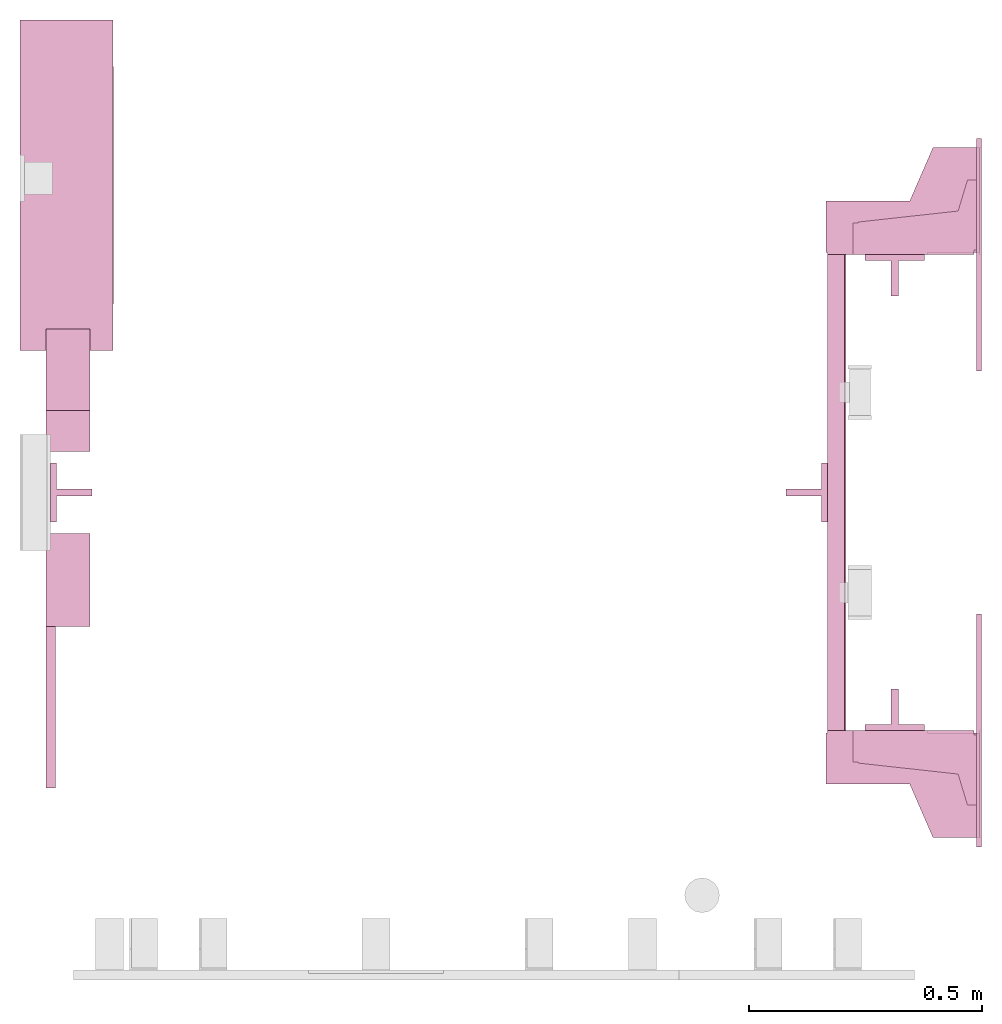
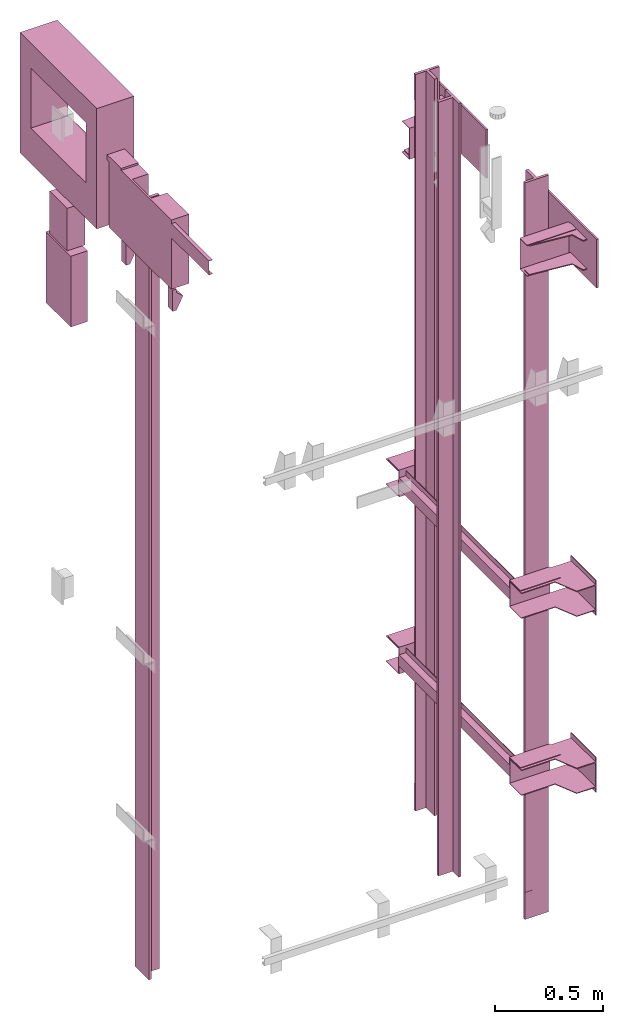
# One storey, part 3 of 4: 9 transport elements.
"""IFC4 building model written with IfcOpenShell, lengths in millimetres."""

from ifc_helpers import new_model, entity, si_unit, converted_unit, frame, origin_with_axes, place, context, subcontext, project, spatial, faceted_brep, element, save


model = new_model("IFC4")

# Units and contexts
context_of_model = context(None, 3, precision=0.01, world=origin_with_axes())
sub_context_1 = subcontext(context_of_model, None, None, "MODEL_VIEW")
sub_context_2 = subcontext(context_of_model, None, None, "MODEL_VIEW")
sub_context_3 = subcontext(context_of_model, None, None, "MODEL_VIEW")
sub_context_4 = subcontext(context_of_model, None, None, "MODEL_VIEW")
sub_context_5 = subcontext(context_of_model, None, None, "MODEL_VIEW")
sub_context_6 = subcontext(context_of_model, None, None, "MODEL_VIEW")
sub_context_7 = subcontext(context_of_model, None, None, "MODEL_VIEW")
sub_context_8 = subcontext(context_of_model, None, None, "MODEL_VIEW")
sub_context_9 = subcontext(context_of_model, None, None, "MODEL_VIEW")
ifc_project = project(units=[converted_unit("PLANEANGLEUNIT", "degree", entity("IfcPlaneAngleMeasure", 0.017453292519943), si_unit("PLANEANGLEUNIT", "RADIAN"), dimensions=[0, 0, 0, 0, 0, 0, 0]), si_unit("LENGTHUNIT", "METRE", prefix="MILLI"), si_unit("MASSUNIT", "GRAM", prefix="KILO"), converted_unit("TIMEUNIT", "year", entity("IfcTimeMeasure", 31557600.0), si_unit("TIMEUNIT", "SECOND"), dimensions=[0, 0, 1, 0, 0, 0, 0]), si_unit("THERMODYNAMICTEMPERATUREUNIT", "DEGREE_CELSIUS"), si_unit("AREAUNIT", "SQUARE_METRE"), si_unit("FORCEUNIT", "NEWTON"), si_unit("VOLUMEUNIT", "CUBIC_METRE"), si_unit("PRESSUREUNIT", "PASCAL"), si_unit("SOLIDANGLEUNIT", "STERADIAN")], contexts=[context_of_model])

# Site, building, storey
site = spatial("IfcSite", under=ifc_project)
building = spatial("IfcBuilding", under=site, Name="Document")
placement = place(None, origin_with_axes())
storey_placement = place(placement, frame((0.0, 0.0, 4420.0), z_axis=(0.0, 0.0, 1.0), x_axis=(1.0, 0.0, 0.0)))
storey = spatial("IfcBuildingStorey", under=building, at=storey_placement, Name="1", Elevation=4420.0)

# Transport elements
transport_element_1_placement = place(storey_placement, frame((2065.0, 1025.0, 64.0), z_axis=(0.0, 0.0, 1.0), x_axis=(0.0, 1.0, 0.0)))
element("IfcTransportElement", 1, at=transport_element_1_placement, inside=storey, PredefinedType="ELEVATOR", context=sub_context_1, shape_type="Brep", body=[
    faceted_brep([(-511.0, 291.0, -32.5), (-511.0, 294.0, -32.5), (-511.0, 294.0, -59.5), (-511.0, 291.0, -59.5), (511.0, 291.0, -32.5), (511.0, 291.0, -59.5), (511.0, 294.0, -59.5), (511.0, 294.0, -32.5)], [[[0, 1, 2, 3]], [[4, 5, 6, 7]], [[0, 3, 5, 4]], [[3, 2, 6, 5]], [[2, 1, 7, 6]], [[1, 0, 4, 7]]]),
    faceted_brep([(-511.0, 291.0, 59.5), (-511.0, 294.0, 59.5), (-511.0, 294.0, 32.5), (-511.0, 291.0, 32.5), (511.0, 291.0, 59.5), (511.0, 291.0, 32.5), (511.0, 294.0, 32.5), (511.0, 294.0, 59.5)], [[[0, 1, 2, 3]], [[4, 5, 6, 7]], [[0, 3, 5, 4]], [[3, 2, 6, 5]], [[2, 1, 7, 6]], [[1, 0, 4, 7]]]),
    faceted_brep([(-611.0, 331.0, -72.5), (-514.0, 331.0, -72.5), (-514.0, 331.0, 72.5), (-611.0, 331.0, 72.5), (-611.0, 331.0, 75.5), (-511.0, 331.0, 75.5), (-511.0, 331.0, -75.5), (-611.0, 331.0, -75.5), (-511.0, 116.0, -75.5), (-511.0, 116.0, 75.5), (-611.0, 116.0, 75.5), (-611.0, 116.0, 72.5), (-514.0, 116.0, 72.5), (-514.0, 116.0, -72.5), (-611.0, 116.0, -72.5), (-611.0, 116.0, -75.5)], [[[0, 1, 2, 3, 4, 5, 6, 7]], [[8, 9, 10, 11, 12, 13, 14, 15]], [[15, 14, 0, 7]], [[13, 12, 2, 1]], [[5, 9, 8, 6]], [[11, 10, 4, 3]], [[6, 8, 15, 7]], [[14, 13, 1, 0]], [[2, 12, 11, 3]], [[10, 9, 5, 4]]]),
    faceted_brep([(-511.0, 331.0, 32.5), (511.0, 331.0, 32.5), (511.0, 331.0, -32.5), (-511.0, 331.0, -32.5), (511.0, 328.0, -29.5), (511.0, 328.0, 29.5), (-511.0, 328.0, 29.5), (-511.0, 328.0, -29.5), (511.0, 291.0, -32.5), (511.0, 291.0, -29.5), (-511.0, 291.0, -29.5), (-511.0, 291.0, -32.5), (511.0, 291.0, 29.5), (511.0, 291.0, 32.5), (-511.0, 291.0, 32.5), (-511.0, 291.0, 29.5)], [[[0, 1, 2, 3]], [[4, 5, 6, 7]], [[8, 9, 10, 11]], [[12, 13, 14, 15]], [[11, 10, 7, 6, 15, 14, 0, 3]], [[2, 1, 13, 12, 5, 4, 9, 8]], [[2, 8, 11, 3]], [[10, 9, 4, 7]], [[14, 13, 1, 0]], [[5, 12, 15, 6]]]),
    faceted_brep([(516.0, 334.0, 72.5), (626.0, 334.0, 72.5), (626.0, 334.0, 68.5), (516.0, 334.0, 68.5), (741.0, 4.0, 68.5), (741.0, 4.0, 72.5), (516.0, 4.0, 72.5), (516.0, 4.0, 68.5), (626.0, 154.0, 72.5), (741.0, 104.0, 72.5), (741.0, 104.0, 68.5), (626.0, 154.0, 68.5)], [[[0, 1, 2, 3]], [[4, 5, 6, 7]], [[8, 9, 10, 11]], [[7, 6, 0, 3]], [[1, 8, 11, 2]], [[9, 5, 4, 10]], [[2, 11, 10, 4, 7, 3]], [[6, 5, 9, 8, 1, 0]]]),
    faceted_brep([(516.0, 334.0, -68.5), (626.0, 334.0, -68.5), (626.0, 334.0, -72.5), (516.0, 334.0, -72.5), (741.0, 4.0, -72.5), (741.0, 4.0, -68.5), (516.0, 4.0, -68.5), (516.0, 4.0, -72.5), (626.0, 154.0, -68.5), (741.0, 104.0, -68.5), (741.0, 104.0, -72.5), (626.0, 154.0, -72.5)], [[[0, 1, 2, 3]], [[4, 5, 6, 7]], [[8, 9, 10, 11]], [[7, 6, 0, 3]], [[1, 8, 11, 2]], [[9, 5, 4, 10]], [[2, 11, 10, 4, 7, 3]], [[6, 5, 9, 8, 1, 0]]]),
    faceted_brep([(-626.0, 334.0, -68.5), (-516.0, 334.0, -68.5), (-516.0, 334.0, -72.5), (-626.0, 334.0, -72.5), (-516.0, 4.0, -72.5), (-516.0, 4.0, -68.5), (-741.0, 4.0, -68.5), (-741.0, 4.0, -72.5), (-741.0, 104.0, -68.5), (-626.0, 154.0, -68.5), (-626.0, 154.0, -72.5), (-741.0, 104.0, -72.5)], [[[0, 1, 2, 3]], [[4, 5, 6, 7]], [[8, 9, 10, 11]], [[10, 9, 0, 3]], [[1, 5, 4, 2]], [[7, 6, 8, 11]], [[2, 4, 7, 11, 10, 3]], [[9, 8, 6, 5, 1, 0]]]),
    faceted_brep([(-626.0, 334.0, 72.5), (-516.0, 334.0, 72.5), (-516.0, 334.0, 68.5), (-626.0, 334.0, 68.5), (-516.0, 4.0, 68.5), (-516.0, 4.0, 72.5), (-741.0, 4.0, 72.5), (-741.0, 4.0, 68.5), (-741.0, 104.0, 72.5), (-626.0, 154.0, 72.5), (-626.0, 154.0, 68.5), (-741.0, 104.0, 68.5)], [[[0, 1, 2, 3]], [[4, 5, 6, 7]], [[8, 9, 10, 11]], [[10, 9, 0, 3]], [[1, 5, 4, 2]], [[7, 6, 8, 11]], [[2, 4, 7, 11, 10, 3]], [[9, 8, 6, 5, 1, 0]]]),
    faceted_brep([(511.0, 331.0, 75.5), (611.0, 331.0, 75.5), (611.0, 331.0, 72.5), (514.0, 331.0, 72.5), (514.0, 331.0, -72.5), (611.0, 331.0, -72.5), (611.0, 331.0, -75.5), (511.0, 331.0, -75.5), (511.0, 116.0, -75.5), (611.0, 116.0, -75.5), (611.0, 116.0, -72.5), (514.0, 116.0, -72.5), (514.0, 116.0, 72.5), (611.0, 116.0, 72.5), (611.0, 116.0, 75.5), (511.0, 116.0, 75.5)], [[[0, 1, 2, 3, 4, 5, 6, 7]], [[8, 9, 10, 11, 12, 13, 14, 15]], [[8, 15, 0, 7]], [[3, 12, 11, 4]], [[5, 10, 9, 6]], [[1, 14, 13, 2]], [[6, 9, 8, 7]], [[11, 10, 5, 4]], [[15, 14, 1, 0]], [[2, 13, 12, 3]]]),
    faceted_brep([(-511.0, 0.0, -100.0), (-511.0, 0.0, 100.0), (-741.0, 0.0, 100.0), (-741.0, 0.0, -100.0), (-511.0, 4.0, -100.0), (-741.0, 4.0, -100.0), (-741.0, 4.0, 100.0), (-511.0, 4.0, 100.0)], [[[0, 1, 2, 3]], [[4, 5, 6, 7]], [[0, 3, 5, 4]], [[3, 2, 6, 5]], [[2, 1, 7, 6]], [[1, 0, 4, 7]]]),
    faceted_brep([(741.0, 0.0, -100.0), (741.0, 0.0, 100.0), (511.0, 0.0, 100.0), (511.0, 0.0, -100.0), (741.0, 4.0, -100.0), (511.0, 4.0, -100.0), (511.0, 4.0, 100.0), (741.0, 4.0, 100.0)], [[[0, 1, 2, 3]], [[4, 5, 6, 7]], [[0, 3, 5, 4]], [[3, 2, 6, 5]], [[2, 1, 7, 6]], [[1, 0, 4, 7]]]),
])
transport_element_2_placement = place(storey_placement, frame((2065.0, 1025.0, 1064.0), z_axis=(0.0, 0.0, 1.0), x_axis=(0.0, 1.0, 0.0)))
element("IfcTransportElement", 2, at=transport_element_2_placement, inside=storey, PredefinedType="ELEVATOR", context=sub_context_2, shape_type="Brep", body=[
    faceted_brep([(-511.0, 291.0, -32.5), (-511.0, 294.0, -32.5), (-511.0, 294.0, -59.5), (-511.0, 291.0, -59.5), (511.0, 291.0, -32.5), (511.0, 291.0, -59.5), (511.0, 294.0, -59.5), (511.0, 294.0, -32.5)], [[[0, 1, 2, 3]], [[4, 5, 6, 7]], [[0, 3, 5, 4]], [[3, 2, 6, 5]], [[2, 1, 7, 6]], [[1, 0, 4, 7]]]),
    faceted_brep([(-511.0, 331.0, 32.5), (511.0, 331.0, 32.5), (511.0, 331.0, -32.5), (-511.0, 331.0, -32.5), (511.0, 328.0, -29.5), (511.0, 328.0, 29.5), (-511.0, 328.0, 29.5), (-511.0, 328.0, -29.5), (511.0, 291.0, -32.5), (511.0, 291.0, -29.5), (-511.0, 291.0, -29.5), (-511.0, 291.0, -32.5), (511.0, 291.0, 29.5), (511.0, 291.0, 32.5), (-511.0, 291.0, 32.5), (-511.0, 291.0, 29.5)], [[[0, 1, 2, 3]], [[4, 5, 6, 7]], [[8, 9, 10, 11]], [[12, 13, 14, 15]], [[11, 10, 7, 6, 15, 14, 0, 3]], [[2, 1, 13, 12, 5, 4, 9, 8]], [[2, 8, 11, 3]], [[10, 9, 4, 7]], [[14, 13, 1, 0]], [[5, 12, 15, 6]]]),
    faceted_brep([(-611.0, 331.0, -72.5), (-514.0, 331.0, -72.5), (-514.0, 331.0, 72.5), (-611.0, 331.0, 72.5), (-611.0, 331.0, 75.5), (-511.0, 331.0, 75.5), (-511.0, 331.0, -75.5), (-611.0, 331.0, -75.5), (-511.0, 116.0, -75.5), (-511.0, 116.0, 75.5), (-611.0, 116.0, 75.5), (-611.0, 116.0, 72.5), (-514.0, 116.0, 72.5), (-514.0, 116.0, -72.5), (-611.0, 116.0, -72.5), (-611.0, 116.0, -75.5)], [[[0, 1, 2, 3, 4, 5, 6, 7]], [[8, 9, 10, 11, 12, 13, 14, 15]], [[15, 14, 0, 7]], [[13, 12, 2, 1]], [[5, 9, 8, 6]], [[11, 10, 4, 3]], [[6, 8, 15, 7]], [[14, 13, 1, 0]], [[2, 12, 11, 3]], [[10, 9, 5, 4]]]),
    faceted_brep([(-511.0, 291.0, 59.5), (-511.0, 294.0, 59.5), (-511.0, 294.0, 32.5), (-511.0, 291.0, 32.5), (511.0, 291.0, 59.5), (511.0, 291.0, 32.5), (511.0, 294.0, 32.5), (511.0, 294.0, 59.5)], [[[0, 1, 2, 3]], [[4, 5, 6, 7]], [[0, 3, 5, 4]], [[3, 2, 6, 5]], [[2, 1, 7, 6]], [[1, 0, 4, 7]]]),
    faceted_brep([(-626.0, 334.0, -68.5), (-516.0, 334.0, -68.5), (-516.0, 334.0, -72.5), (-626.0, 334.0, -72.5), (-516.0, 4.0, -72.5), (-516.0, 4.0, -68.5), (-741.0, 4.0, -68.5), (-741.0, 4.0, -72.5), (-741.0, 104.0, -68.5), (-626.0, 154.0, -68.5), (-626.0, 154.0, -72.5), (-741.0, 104.0, -72.5)], [[[0, 1, 2, 3]], [[4, 5, 6, 7]], [[8, 9, 10, 11]], [[10, 9, 0, 3]], [[1, 5, 4, 2]], [[7, 6, 8, 11]], [[2, 4, 7, 11, 10, 3]], [[9, 8, 6, 5, 1, 0]]]),
    faceted_brep([(516.0, 334.0, 72.5), (626.0, 334.0, 72.5), (626.0, 334.0, 68.5), (516.0, 334.0, 68.5), (741.0, 4.0, 68.5), (741.0, 4.0, 72.5), (516.0, 4.0, 72.5), (516.0, 4.0, 68.5), (626.0, 154.0, 72.5), (741.0, 104.0, 72.5), (741.0, 104.0, 68.5), (626.0, 154.0, 68.5)], [[[0, 1, 2, 3]], [[4, 5, 6, 7]], [[8, 9, 10, 11]], [[7, 6, 0, 3]], [[1, 8, 11, 2]], [[9, 5, 4, 10]], [[2, 11, 10, 4, 7, 3]], [[6, 5, 9, 8, 1, 0]]]),
    faceted_brep([(516.0, 334.0, -68.5), (626.0, 334.0, -68.5), (626.0, 334.0, -72.5), (516.0, 334.0, -72.5), (741.0, 4.0, -72.5), (741.0, 4.0, -68.5), (516.0, 4.0, -68.5), (516.0, 4.0, -72.5), (626.0, 154.0, -68.5), (741.0, 104.0, -68.5), (741.0, 104.0, -72.5), (626.0, 154.0, -72.5)], [[[0, 1, 2, 3]], [[4, 5, 6, 7]], [[8, 9, 10, 11]], [[7, 6, 0, 3]], [[1, 8, 11, 2]], [[9, 5, 4, 10]], [[2, 11, 10, 4, 7, 3]], [[6, 5, 9, 8, 1, 0]]]),
    faceted_brep([(511.0, 331.0, 75.5), (611.0, 331.0, 75.5), (611.0, 331.0, 72.5), (514.0, 331.0, 72.5), (514.0, 331.0, -72.5), (611.0, 331.0, -72.5), (611.0, 331.0, -75.5), (511.0, 331.0, -75.5), (511.0, 116.0, -75.5), (611.0, 116.0, -75.5), (611.0, 116.0, -72.5), (514.0, 116.0, -72.5), (514.0, 116.0, 72.5), (611.0, 116.0, 72.5), (611.0, 116.0, 75.5), (511.0, 116.0, 75.5)], [[[0, 1, 2, 3, 4, 5, 6, 7]], [[8, 9, 10, 11, 12, 13, 14, 15]], [[8, 15, 0, 7]], [[3, 12, 11, 4]], [[5, 10, 9, 6]], [[1, 14, 13, 2]], [[6, 9, 8, 7]], [[11, 10, 5, 4]], [[15, 14, 1, 0]], [[2, 13, 12, 3]]]),
    faceted_brep([(-626.0, 334.0, 72.5), (-516.0, 334.0, 72.5), (-516.0, 334.0, 68.5), (-626.0, 334.0, 68.5), (-516.0, 4.0, 68.5), (-516.0, 4.0, 72.5), (-741.0, 4.0, 72.5), (-741.0, 4.0, 68.5), (-741.0, 104.0, 72.5), (-626.0, 154.0, 72.5), (-626.0, 154.0, 68.5), (-741.0, 104.0, 68.5)], [[[0, 1, 2, 3]], [[4, 5, 6, 7]], [[8, 9, 10, 11]], [[10, 9, 0, 3]], [[1, 5, 4, 2]], [[7, 6, 8, 11]], [[2, 4, 7, 11, 10, 3]], [[9, 8, 6, 5, 1, 0]]]),
    faceted_brep([(741.0, 0.0, -100.0), (741.0, 0.0, 100.0), (511.0, 0.0, 100.0), (511.0, 0.0, -100.0), (741.0, 4.0, -100.0), (511.0, 4.0, -100.0), (511.0, 4.0, 100.0), (741.0, 4.0, 100.0)], [[[0, 1, 2, 3]], [[4, 5, 6, 7]], [[0, 3, 5, 4]], [[3, 2, 6, 5]], [[2, 1, 7, 6]], [[1, 0, 4, 7]]]),
    faceted_brep([(-511.0, 0.0, -100.0), (-511.0, 0.0, 100.0), (-741.0, 0.0, 100.0), (-741.0, 0.0, -100.0), (-511.0, 4.0, -100.0), (-741.0, 4.0, -100.0), (-741.0, 4.0, 100.0), (-511.0, 4.0, 100.0)], [[[0, 1, 2, 3]], [[4, 5, 6, 7]], [[0, 3, 5, 4]], [[3, 2, 6, 5]], [[2, 1, 7, 6]], [[1, 0, 4, 7]]]),
])
transport_element_3_placement = place(storey_placement, frame((2065.0, 1025.0, 2964.0), z_axis=(0.0, 0.0, 1.0), x_axis=(0.0, 1.0, 0.0)))
element("IfcTransportElement", 3, at=transport_element_3_placement, inside=storey, PredefinedType="ELEVATOR", context=sub_context_3, shape_type="Brep", body=[
    faceted_brep([(-761.0, 0.0, -137.5), (-761.0, 0.0, 137.5), (-761.0, 10.0, 137.5), (-761.0, 10.0, -137.5), (-261.0, 0.0, -137.5), (-261.0, 10.0, -137.5), (-261.0, 10.0, 137.5), (-261.0, 0.0, 137.5)], [[[0, 1, 2, 3]], [[4, 5, 6, 7]], [[0, 3, 5, 4]], [[3, 2, 6, 5]], [[2, 1, 7, 6]], [[1, 0, 4, 7]]]),
    faceted_brep([(511.0, 276.0, 88.0), (579.0, 276.0, 88.0), (579.0, 276.0, 85.0), (514.0, 276.0, 85.0), (514.0, 276.0, -85.0), (579.0, 276.0, -85.0), (579.0, 276.0, -88.0), (511.0, 276.0, -88.0), (511.0, 16.0, -88.0), (579.0, 16.0, -88.0), (579.0, 16.0, -85.0), (514.0, 16.0, -85.0), (514.0, 16.0, 85.0), (579.0, 16.0, 85.0), (579.0, 16.0, 88.0), (511.0, 16.0, 88.0)], [[[0, 1, 2, 3, 4, 5, 6, 7]], [[8, 9, 10, 11, 12, 13, 14, 15]], [[8, 15, 0, 7]], [[3, 12, 11, 4]], [[5, 10, 9, 6]], [[1, 14, 13, 2]], [[6, 9, 8, 7]], [[11, 10, 5, 4]], [[15, 14, 1, 0]], [[2, 13, 12, 3]]]),
    faceted_brep([(-581.0, 265.0, -80.0), (-536.0, 265.0, -80.0), (-536.0, 265.0, -85.0), (-581.0, 265.0, -85.0), (-521.0, 10.0, -85.0), (-521.0, 10.0, -80.0), (-671.0, 10.0, -80.0), (-671.0, 10.0, -85.0), (-671.0, 30.0, -80.0), (-604.7000122070312, 50.0, -80.0), (-604.7000122070312, 50.0, -85.0), (-671.0, 30.0, -85.0), (-536.0, 50.0, -80.0), (-521.0, 35.0, -80.0), (-521.0, 35.0, -85.0), (-536.0, 50.0, -85.0)], [[[0, 1, 2, 3]], [[4, 5, 6, 7]], [[8, 9, 10, 11]], [[12, 13, 14, 15]], [[1, 12, 15, 2]], [[7, 6, 8, 11]], [[13, 5, 4, 14]], [[2, 15, 14, 4, 7, 11, 10, 3]], [[9, 8, 6, 5, 13, 12, 1, 0]], [[10, 9, 0, 3]]]),
    faceted_brep([(536.0, 265.0, -80.0), (581.0, 265.0, -80.0), (581.0, 265.0, -85.0), (536.0, 265.0, -85.0), (671.0, 10.0, -85.0), (671.0, 10.0, -80.0), (521.0, 10.0, -80.0), (521.0, 10.0, -85.0), (604.699951171875, 50.0, -80.0), (671.0, 30.0, -80.0), (671.0, 30.0, -85.0), (604.699951171875, 50.0, -85.0), (521.0, 35.0, -85.0), (521.0, 35.0, -80.0), (536.0, 50.0, -80.0), (536.0, 50.0, -85.0)], [[[0, 1, 2, 3]], [[4, 5, 6, 7]], [[8, 9, 10, 11]], [[12, 13, 14, 15]], [[15, 14, 0, 3]], [[7, 6, 13, 12]], [[9, 5, 4, 10]], [[2, 11, 10, 4, 7, 12, 15, 3]], [[14, 13, 6, 5, 9, 8, 1, 0]], [[1, 8, 11, 2]]]),
    faceted_brep([(671.0, 0.0, -80.0), (671.0, 0.0, 80.0), (521.0, 0.0, 80.0), (521.0, 0.0, -80.0), (671.0, 5.0, -80.0), (521.0, 5.0, -80.0), (521.0, 5.0, 80.0), (671.0, 5.0, 80.0)], [[[0, 1, 2, 3]], [[4, 5, 6, 7]], [[0, 3, 5, 4]], [[3, 2, 6, 5]], [[2, 1, 7, 6]], [[1, 0, 4, 7]]]),
    faceted_brep([(-581.0, 265.0, 85.0), (-536.0, 265.0, 85.0), (-536.0, 265.0, 80.0), (-581.0, 265.0, 80.0), (-521.0, 10.0, 80.0), (-521.0, 10.0, 85.0), (-671.0, 10.0, 85.0), (-671.0, 10.0, 80.0), (-671.0, 30.0, 85.0), (-604.7000122070312, 50.0, 85.0), (-604.7000122070312, 50.0, 80.0), (-671.0, 30.0, 80.0), (-536.0, 50.0, 85.0), (-521.0, 35.0, 85.0), (-521.0, 35.0, 80.0), (-536.0, 50.0, 80.0)], [[[0, 1, 2, 3]], [[4, 5, 6, 7]], [[8, 9, 10, 11]], [[12, 13, 14, 15]], [[1, 12, 15, 2]], [[7, 6, 8, 11]], [[13, 5, 4, 14]], [[2, 15, 14, 4, 7, 11, 10, 3]], [[9, 8, 6, 5, 13, 12, 1, 0]], [[10, 9, 0, 3]]]),
    faceted_brep([(-521.0, 0.0, -80.0), (-521.0, 0.0, 80.0), (-671.0, 0.0, 80.0), (-671.0, 0.0, -80.0), (-521.0, 5.0, -80.0), (-671.0, 5.0, -80.0), (-671.0, 5.0, 80.0), (-521.0, 5.0, 80.0)], [[[0, 1, 2, 3]], [[4, 5, 6, 7]], [[0, 3, 5, 4]], [[3, 2, 6, 5]], [[2, 1, 7, 6]], [[1, 0, 4, 7]]]),
    faceted_brep([(536.0, 265.0, 85.0), (581.0, 265.0, 85.0), (581.0, 265.0, 80.0), (536.0, 265.0, 80.0), (671.0, 10.0, 80.0), (671.0, 10.0, 85.0), (521.0, 10.0, 85.0), (521.0, 10.0, 80.0), (604.699951171875, 50.0, 85.0), (671.0, 30.0, 85.0), (671.0, 30.0, 80.0), (604.699951171875, 50.0, 80.0), (521.0, 35.0, 80.0), (521.0, 35.0, 85.0), (536.0, 50.0, 85.0), (536.0, 50.0, 80.0)], [[[0, 1, 2, 3]], [[4, 5, 6, 7]], [[8, 9, 10, 11]], [[12, 13, 14, 15]], [[15, 14, 0, 3]], [[7, 6, 13, 12]], [[9, 5, 4, 10]], [[2, 11, 10, 4, 7, 12, 15, 3]], [[14, 13, 6, 5, 9, 8, 1, 0]], [[1, 8, 11, 2]]]),
    faceted_brep([(-579.0, 276.0, -85.0), (-514.0, 276.0, -85.0), (-514.0, 276.0, 85.0), (-579.0, 276.0, 85.0), (-579.0, 276.0, 88.0), (-511.0, 276.0, 88.0), (-511.0, 276.0, -88.0), (-579.0, 276.0, -88.0), (-511.0, 16.0, -88.0), (-511.0, 16.0, 88.0), (-579.0, 16.0, 88.0), (-579.0, 16.0, 85.0), (-514.0, 16.0, 85.0), (-514.0, 16.0, -85.0), (-579.0, 16.0, -85.0), (-579.0, 16.0, -88.0)], [[[0, 1, 2, 3, 4, 5, 6, 7]], [[8, 9, 10, 11, 12, 13, 14, 15]], [[15, 14, 0, 7]], [[13, 12, 2, 1]], [[5, 9, 8, 6]], [[11, 10, 4, 3]], [[6, 8, 15, 7]], [[14, 13, 1, 0]], [[2, 12, 11, 3]], [[10, 9, 5, 4]]]),
    faceted_brep([(261.0, 0.0, -137.5), (261.0, 0.0, 137.5), (261.0, 10.0, 137.5), (261.0, 10.0, -137.5), (761.0, 0.0, -137.5), (761.0, 10.0, -137.5), (761.0, 10.0, 137.5), (761.0, 0.0, 137.5)], [[[0, 1, 2, 3]], [[4, 5, 6, 7]], [[0, 3, 5, 4]], [[3, 2, 6, 5]], [[2, 1, 7, 6]], [[1, 0, 4, 7]]]),
])
transport_element_4_placement = place(storey_placement, frame((1879.0, 558.5, 1273.5), z_axis=(0.0, -1.0, 0.0), x_axis=(0.0, 0.0, -1.0)))
element("IfcTransportElement", 4, at=transport_element_4_placement, inside=storey, ObjectType="Guide Rail", PredefinedType="ELEVATOR", context=sub_context_4, shape_type="Brep", body=[
    faceted_brep([(-2080.5, -63.5, 45.0), (-2080.5, 63.5, 45.0), (-2080.5, 63.5, 44.0), (-2080.5, -63.5, 44.0), (-1928.0, -63.5, 45.0), (-1928.0, -63.5, 44.0), (-1928.0, 63.5, 44.0), (-1928.0, 63.5, 45.0)], [[[0, 1, 2, 3]], [[4, 5, 6, 7]], [[0, 3, 5, 4]], [[3, 2, 6, 5]], [[2, 1, 7, 6]], [[1, 0, 4, 7]]]),
    faceted_brep([(1928.0, -63.5, 45.0), (1928.0, 63.5, 45.0), (1928.0, 63.5, 44.0), (1928.0, -63.5, 44.0), (2080.5, -63.5, 45.0), (2080.5, -63.5, 44.0), (2080.5, 63.5, 44.0), (2080.5, 63.5, 45.0)], [[[0, 1, 2, 3]], [[4, 5, 6, 7]], [[0, 3, 5, 4]], [[3, 2, 6, 5]], [[2, 1, 7, 6]], [[1, 0, 4, 7]]]),
    faceted_brep([(-2080.5, -63.5, 44.5), (-2080.5, -63.5, 31.79998779296875), (2080.5, -63.5, 31.79998779296875), (2080.5, -63.5, 44.5), (-2080.5, -7.93994140625, 31.79998779296875), (-2080.5, -7.93994140625, -44.5), (2080.5, -7.93994140625, -44.5), (2080.5, -7.93994140625, 31.79998779296875), (2080.5, 7.93994140625, -44.5), (-2080.5, 7.93994140625, -44.5), (-2080.5, 7.93994140625, 31.79998779296875), (2080.5, 7.93994140625, 31.79998779296875), (2080.5, 63.5, 31.79998779296875), (-2080.5, 63.5, 31.79998779296875), (-2080.5, 63.5, 44.5), (2080.5, 63.5, 44.5)], [[[0, 1, 2, 3]], [[4, 5, 6, 7]], [[8, 9, 10, 11]], [[12, 13, 14, 15]], [[15, 14, 0, 3]], [[1, 4, 7, 2]], [[10, 13, 12, 11]], [[5, 9, 8, 6]], [[2, 7, 6, 8, 11, 12, 15, 3]], [[14, 13, 10, 9, 5, 4, 1, 0]]]),
])
transport_element_5_placement = place(storey_placement, frame((1879.0, 1491.5, 1273.5), z_axis=(0.0, 1.0, 0.0), x_axis=(0.0, 0.0, 1.0)))
element("IfcTransportElement", 5, at=transport_element_5_placement, inside=storey, ObjectType="Guide Rail", PredefinedType="ELEVATOR", context=sub_context_5, shape_type="Brep", body=[
    faceted_brep([(1928.0, -63.5, 45.0), (1928.0, 63.5, 45.0), (1928.0, 63.5, 44.0), (1928.0, -63.5, 44.0), (2080.5, -63.5, 45.0), (2080.5, -63.5, 44.0), (2080.5, 63.5, 44.0), (2080.5, 63.5, 45.0)], [[[0, 1, 2, 3]], [[4, 5, 6, 7]], [[0, 3, 5, 4]], [[3, 2, 6, 5]], [[2, 1, 7, 6]], [[1, 0, 4, 7]]]),
    faceted_brep([(-2080.5, -63.5, 45.0), (-2080.5, 63.5, 45.0), (-2080.5, 63.5, 44.0), (-2080.5, -63.5, 44.0), (-1928.0, -63.5, 45.0), (-1928.0, -63.5, 44.0), (-1928.0, 63.5, 44.0), (-1928.0, 63.5, 45.0)], [[[0, 1, 2, 3]], [[4, 5, 6, 7]], [[0, 3, 5, 4]], [[3, 2, 6, 5]], [[2, 1, 7, 6]], [[1, 0, 4, 7]]]),
    faceted_brep([(2080.5, -63.5, 31.800048828125), (2080.5, -63.5, 44.5), (-2080.5, -63.5, 44.5), (-2080.5, -63.5, 31.800048828125), (2080.5, -7.93994140625, -44.5), (2080.5, -7.93994140625, 31.800048828125), (-2080.5, -7.93994140625, 31.800048828125), (-2080.5, -7.93994140625, -44.5), (-2080.5, 7.93994140625, 31.800048828125), (2080.5, 7.93994140625, 31.800048828125), (2080.5, 7.93994140625, -44.5), (-2080.5, 7.93994140625, -44.5), (-2080.5, 63.5, 44.5), (2080.5, 63.5, 44.5), (2080.5, 63.5, 31.800048828125), (-2080.5, 63.5, 31.800048828125)], [[[0, 1, 2, 3]], [[4, 5, 6, 7]], [[8, 9, 10, 11]], [[12, 13, 14, 15]], [[6, 5, 0, 3]], [[1, 13, 12, 2]], [[11, 10, 4, 7]], [[9, 8, 15, 14]], [[2, 12, 15, 8, 11, 7, 6, 3]], [[5, 4, 10, 9, 14, 13, 1, 0]]]),
])
transport_element_6_placement = place(storey_placement, frame((110.5, 1025.0, 1378.5), z_axis=(-1.0, 0.0, 0.0), x_axis=(0.0, 0.0, -1.0)))
element("IfcTransportElement", 6, at=transport_element_6_placement, inside=storey, ObjectType="Guide Rail", PredefinedType="ELEVATOR", context=sub_context_6, shape_type="Brep", body=[
    faceted_brep([(2033.0, -63.5, 45.0), (2033.0, 63.5, 45.0), (2033.0, 63.5, 44.0), (2033.0, -63.5, 44.0), (2185.5, -63.5, 45.0), (2185.5, -63.5, 44.0), (2185.5, 63.5, 44.0), (2185.5, 63.5, 45.0)], [[[0, 1, 2, 3]], [[4, 5, 6, 7]], [[0, 3, 5, 4]], [[3, 2, 6, 5]], [[2, 1, 7, 6]], [[1, 0, 4, 7]]]),
    faceted_brep([(-2185.5, -63.5, 45.0), (-2185.5, 63.5, 45.0), (-2185.5, 63.5, 44.0), (-2185.5, -63.5, 44.0), (-2033.0, -63.5, 45.0), (-2033.0, -63.5, 44.0), (-2033.0, 63.5, 44.0), (-2033.0, 63.5, 45.0)], [[[0, 1, 2, 3]], [[4, 5, 6, 7]], [[0, 3, 5, 4]], [[3, 2, 6, 5]], [[2, 1, 7, 6]], [[1, 0, 4, 7]]]),
    faceted_brep([(-2185.5, 63.5, 44.5), (-2185.5, -63.5, 44.5), (2185.5, -63.5, 44.5), (2185.5, 63.5, 44.5), (2185.5, 7.94000244140625, 31.800003051757812), (-2185.5, 7.94000244140625, 31.800003051757812), (-2185.5, 63.5, 31.800003051757812), (2185.5, 63.5, 31.800003051757812), (2185.5, -63.5, 31.800003051757812), (-2185.5, -63.5, 31.800003051757812), (-2185.5, -7.93994140625, 31.800003051757812), (2185.5, -7.93994140625, 31.800003051757812), (2185.5, -7.93994140625, -44.5), (-2185.5, -7.93994140625, -44.5), (-2185.5, 7.94000244140625, -44.5), (2185.5, 7.94000244140625, -44.5)], [[[0, 1, 2, 3]], [[4, 5, 6, 7]], [[8, 9, 10, 11]], [[12, 13, 14, 15]], [[7, 6, 0, 3]], [[15, 14, 5, 4]], [[10, 13, 12, 11]], [[1, 9, 8, 2]], [[2, 8, 11, 12, 15, 4, 7, 3]], [[6, 5, 14, 13, 10, 9, 1, 0]]]),
])
transport_element_7_placement = place(storey_placement, frame((1689.5, 1025.0, 1378.5), z_axis=(1.0, 0.0, 0.0), x_axis=(0.0, 0.0, 1.0)))
element("IfcTransportElement", 7, at=transport_element_7_placement, inside=storey, ObjectType="Guide Rail", PredefinedType="ELEVATOR", context=sub_context_7, shape_type="Brep", body=[
    faceted_brep([(2033.0, -63.5, 45.0), (2033.0, 63.5, 45.0), (2033.0, 63.5, 44.0), (2033.0, -63.5, 44.0), (2185.5, -63.5, 45.0), (2185.5, -63.5, 44.0), (2185.5, 63.5, 44.0), (2185.5, 63.5, 45.0)], [[[0, 1, 2, 3]], [[4, 5, 6, 7]], [[0, 3, 5, 4]], [[3, 2, 6, 5]], [[2, 1, 7, 6]], [[1, 0, 4, 7]]]),
    faceted_brep([(-2185.5, -63.5, 45.0), (-2185.5, 63.5, 45.0), (-2185.5, 63.5, 44.0), (-2185.5, -63.5, 44.0), (-2033.0, -63.5, 45.0), (-2033.0, -63.5, 44.0), (-2033.0, 63.5, 44.0), (-2033.0, 63.5, 45.0)], [[[0, 1, 2, 3]], [[4, 5, 6, 7]], [[0, 3, 5, 4]], [[3, 2, 6, 5]], [[2, 1, 7, 6]], [[1, 0, 4, 7]]]),
    faceted_brep([(2185.5, 7.94000244140625, -44.5), (2185.5, -7.93994140625, -44.5), (-2185.5, -7.93994140625, -44.5), (-2185.5, 7.94000244140625, -44.5), (2185.5, 63.5, 31.800048828125), (2185.5, 7.94000244140625, 31.800048828125), (-2185.5, 7.94000244140625, 31.800048828125), (-2185.5, 63.5, 31.800048828125), (-2185.5, -63.5, 44.5), (2185.5, -63.5, 44.5), (2185.5, 63.5, 44.5), (-2185.5, 63.5, 44.5), (2185.5, -7.93994140625, 31.800048828125), (2185.5, -63.5, 31.800048828125), (-2185.5, -63.5, 31.800048828125), (-2185.5, -7.93994140625, 31.800048828125)], [[[0, 1, 2, 3]], [[4, 5, 6, 7]], [[8, 9, 10, 11]], [[12, 13, 14, 15]], [[6, 5, 0, 3]], [[1, 12, 15, 2]], [[11, 10, 4, 7]], [[13, 9, 8, 14]], [[2, 15, 14, 8, 11, 7, 6, 3]], [[5, 4, 10, 9, 13, 12, 1, 0]]]),
])
transport_element_8_placement = place(storey_placement, frame((103.0, 810.0, 3064.0), z_axis=(0.0, 0.0, 1.0), x_axis=(1.0, 0.0, 0.0)))
element("IfcTransportElement", 8, at=transport_element_8_placement, inside=storey, ObjectType="Car FixPoint (Drive R)", PredefinedType="ELEVATOR", context=sub_context_8, shape_type="Brep", body=[
    faceted_brep([(-43.0, -73.0, 560.0), (-43.0, 503.0, 560.0), (-43.0, 503.0, 170.0), (-43.0, -73.0, 170.0), (47.0, 127.0, 170.0), (47.0, 127.0, 560.0), (47.0, -73.0, 560.0), (47.0, -73.0, 170.0), (-37.0, 303.0, 170.0), (-37.0, 303.0, 560.0), (-37.0, 127.0, 560.0), (-37.0, 127.0, 170.0), (47.0, 503.0, 170.0), (47.0, 503.0, 560.0), (47.0, 303.0, 560.0), (47.0, 303.0, 170.0)], [[[0, 1, 2, 3]], [[4, 5, 6, 7]], [[8, 9, 10, 11]], [[12, 13, 14, 15]], [[7, 6, 0, 3]], [[10, 5, 4, 11]], [[15, 14, 9, 8]], [[1, 13, 12, 2]], [[3, 2, 12, 15, 8, 11, 4, 7]], [[6, 5, 10, 9, 14, 13, 1, 0]]]),
    faceted_brep([(-10.0, -22.0, 120.0), (-10.0, 22.0, 120.0), (-10.0, 22.0, 0.0), (-10.0, -22.0, 0.0), (10.0, 22.0, 100.0), (10.0, 22.0, 120.0), (10.0, -22.0, 120.0), (10.0, -22.0, 100.0), (10.0, -22.0, 0.0), (45.0, -22.0, 70.0), (45.0, 22.0, 70.0), (10.0, 22.0, 0.0)], [[[0, 1, 2, 3]], [[4, 5, 6, 7]], [[8, 9, 7, 6, 0, 3]], [[2, 1, 5, 4, 10, 11]], [[2, 11, 8, 3]], [[6, 5, 1, 0]], [[9, 10, 4, 7]], [[11, 10, 9, 8]]]),
    faceted_brep([(-47.0, -73.0, 560.0), (-47.0, 503.0, 560.0), (-47.0, 503.0, 170.0), (-47.0, -73.0, 170.0), (-43.0, -73.0, 560.0), (-43.0, -73.0, 170.0), (-43.0, 503.0, 170.0), (-43.0, 503.0, 560.0)], [[[0, 1, 2, 3]], [[4, 5, 6, 7]], [[0, 3, 5, 4]], [[3, 2, 6, 5]], [[2, 1, 7, 6]], [[1, 0, 4, 7]]]),
    faceted_brep([(-47.0, -420.0, 540.0), (-47.0, -73.0, 540.0), (-47.0, -73.0, 460.0), (-47.0, -420.0, 460.0), (-45.0, -73.0, 462.0), (-45.0, -73.0, 538.0), (-45.0, -420.0, 538.0), (-45.0, -420.0, 462.0), (-27.0, -73.0, 460.0), (-27.0, -73.0, 462.0), (-27.0, -420.0, 462.0), (-27.0, -420.0, 460.0), (-27.0, -73.0, 538.0), (-27.0, -73.0, 540.0), (-27.0, -420.0, 540.0), (-27.0, -420.0, 538.0)], [[[0, 1, 2, 3]], [[4, 5, 6, 7]], [[8, 9, 10, 11]], [[12, 13, 14, 15]], [[3, 11, 10, 7, 6, 15, 14, 0]], [[1, 13, 12, 5, 4, 9, 8, 2]], [[2, 8, 11, 3]], [[10, 9, 4, 7]], [[14, 13, 1, 0]], [[5, 12, 15, 6]]]),
    faceted_brep([(-47.0, 391.0, 570.0), (-47.0, 566.0, 570.0), (-47.0, 566.0, 540.0), (-47.0, 503.0, 540.0), (-47.0, 503.0, 560.0), (-47.0, 391.0, 560.0), (47.0, 503.0, 560.0), (47.0, 503.0, 540.0), (47.0, 566.0, 540.0), (47.0, 566.0, 570.0), (47.0, 391.0, 570.0), (47.0, 391.0, 560.0)], [[[0, 1, 2, 3, 4, 5]], [[6, 7, 8, 9, 10, 11]], [[11, 10, 0, 5]], [[7, 6, 4, 3]], [[1, 9, 8, 2]], [[4, 6, 11, 5]], [[10, 9, 1, 0]], [[2, 8, 7, 3]]]),
    faceted_brep([(-6.0, 0.0, 120.0), (-5.54327392578125, 2.29608154296875, 120.0), (-4.242637634277344, 4.24261474609375, 120.0), (-2.296096801757812, 5.54327392578125, 120.0), (0.0, 6.0, 120.0), (2.296096801757812, 5.54327392578125, 120.0), (4.242637634277344, 4.24261474609375, 120.0), (5.54327392578125, 2.29608154296875, 120.0), (6.0, 0.0, 120.0), (5.54327392578125, -2.29608154296875, 120.0), (4.242637634277344, -4.24261474609375, 120.0), (2.296096801757812, -5.54327392578125, 120.0), (0.0, -6.0, 120.0), (-2.296096801757812, -5.54327392578125, 120.0), (-4.242637634277344, -4.24261474609375, 120.0), (-5.54327392578125, -2.29608154296875, 120.0), (-6.0, 0.0, 480.0), (-5.54327392578125, -2.29608154296875, 480.0), (-4.242637634277344, -4.24261474609375, 480.0), (-2.296096801757812, -5.54327392578125, 480.0), (0.0, -6.0, 480.0), (2.296096801757812, -5.54327392578125, 480.0), (4.242637634277344, -4.24261474609375, 480.0), (5.54327392578125, -2.29608154296875, 480.0), (6.0, 0.0, 480.0), (5.54327392578125, 2.29608154296875, 480.0), (4.242637634277344, 4.24261474609375, 480.0), (2.296096801757812, 5.54327392578125, 480.0), (0.0, 6.0, 480.0), (-2.296096801757812, 5.54327392578125, 480.0), (-4.242637634277344, 4.24261474609375, 480.0), (-5.54327392578125, 2.29608154296875, 480.0)], [[[0, 1, 2, 3, 4, 5, 6, 7, 8, 9, 10, 11, 12, 13, 14, 15]], [[16, 17, 18, 19, 20, 21, 22, 23, 24, 25, 26, 27, 28, 29, 30, 31]], [[0, 15, 17, 16]], [[15, 14, 18, 17]], [[14, 13, 19, 18]], [[13, 12, 20, 19]], [[12, 11, 21, 20]], [[11, 10, 22, 21]], [[10, 9, 23, 22]], [[9, 8, 24, 23]], [[8, 7, 25, 24]], [[7, 6, 26, 25]], [[6, 5, 27, 26]], [[5, 4, 28, 27]], [[4, 3, 29, 28]], [[3, 2, 30, 29]], [[2, 1, 31, 30]], [[1, 0, 16, 31]]]),
    faceted_brep([(-10.0, 408.0, 120.0), (-10.0, 452.0, 120.0), (-10.0, 452.0, 0.0), (-10.0, 408.0, 0.0), (10.0, 452.0, 100.0), (10.0, 452.0, 120.0), (10.0, 408.0, 120.0), (10.0, 408.0, 100.0), (10.0, 408.0, 0.0), (45.0, 408.0, 70.0), (45.0, 452.0, 70.0), (10.0, 452.0, 0.0)], [[[0, 1, 2, 3]], [[4, 5, 6, 7]], [[8, 9, 7, 6, 0, 3]], [[2, 1, 5, 4, 10, 11]], [[2, 11, 8, 3]], [[6, 5, 1, 0]], [[9, 10, 4, 7]], [[11, 10, 9, 8]]]),
    faceted_brep([(-6.0, 430.0, 120.0), (-5.54327392578125, 432.296142578125, 120.0), (-4.242637634277344, 434.24267578125, 120.0), (-2.296096801757812, 435.5433349609375, 120.0), (0.0, 436.0, 120.0), (2.296096801757812, 435.5433349609375, 120.0), (4.242637634277344, 434.24267578125, 120.0), (5.54327392578125, 432.296142578125, 120.0), (6.0, 430.0, 120.0), (5.54327392578125, 427.703857421875, 120.0), (4.242637634277344, 425.75732421875, 120.0), (2.296096801757812, 424.4566650390625, 120.0), (0.0, 424.0, 120.0), (-2.296096801757812, 424.4566650390625, 120.0), (-4.242637634277344, 425.75732421875, 120.0), (-5.54327392578125, 427.703857421875, 120.0), (-6.0, 430.0, 480.0), (-5.54327392578125, 427.703857421875, 480.0), (-4.242637634277344, 425.75732421875, 480.0), (-2.296096801757812, 424.4566650390625, 480.0), (0.0, 424.0, 480.0), (2.296096801757812, 424.4566650390625, 480.0), (4.242637634277344, 425.75732421875, 480.0), (5.54327392578125, 427.703857421875, 480.0), (6.0, 430.0, 480.0), (5.54327392578125, 432.296142578125, 480.0), (4.242637634277344, 434.24267578125, 480.0), (2.296096801757812, 435.5433349609375, 480.0), (0.0, 436.0, 480.0), (-2.296096801757812, 435.5433349609375, 480.0), (-4.242637634277344, 434.24267578125, 480.0), (-5.54327392578125, 432.296142578125, 480.0)], [[[0, 1, 2, 3, 4, 5, 6, 7, 8, 9, 10, 11, 12, 13, 14, 15]], [[16, 17, 18, 19, 20, 21, 22, 23, 24, 25, 26, 27, 28, 29, 30, 31]], [[0, 15, 17, 16]], [[15, 14, 18, 17]], [[14, 13, 19, 18]], [[13, 12, 20, 19]], [[12, 11, 21, 20]], [[11, 10, 22, 21]], [[10, 9, 23, 22]], [[9, 8, 24, 23]], [[8, 7, 25, 24]], [[7, 6, 26, 25]], [[6, 5, 27, 26]], [[5, 4, 28, 27]], [[4, 3, 29, 28]], [[3, 2, 30, 29]], [[2, 1, 31, 30]], [[1, 0, 16, 31]]]),
])
transport_element_9_placement = place(storey_placement, frame((0.0, 1685.0, 3434.0), z_axis=(0.0, 0.0, 1.0), x_axis=(0.0, 1.0, 0.0)))
element("IfcTransportElement", 9, at=transport_element_9_placement, inside=storey, Name="Shaft0", PredefinedType="ELEVATOR", context=sub_context_9, shape_type="Brep", body=[
    faceted_brep([(-255.0, -200.99999999999994, 0.0), (-255.0, -200.99999999999994, 1.0), (-255.0, -1e-14, -199.0), (-255.0, -1e-14, -200.0), (255.0, -201.00000000000006, 0.0), (255.0, 1e-14, -200.0), (255.0, 1e-14, -199.0), (255.0, -201.00000000000006, 1.0)], [[[0, 1, 2, 3]], [[4, 5, 6, 7]], [[4, 0, 3, 5]], [[5, 3, 2, 6]], [[6, 2, 1, 7]], [[7, 1, 0, 4]]]),
    faceted_brep([(115.0, -90.00000000000001, -900.0), (115.0, 0.0, -900.0), (115.0, 0.0, -500.0), (115.0, -90.00000000000001, -500.0), (-115.0, -89.99999999999997, -900.0), (-115.0, -89.99999999999997, -500.0), (-115.0, 0.0, -500.0), (-115.0, 0.0, -900.0)], [[[0, 1, 2, 3]], [[4, 5, 6, 7]], [[0, 3, 5, 4]], [[3, 2, 6, 5]], [[2, 1, 7, 6]], [[1, 0, 4, 7]]]),
    faceted_brep([(255.0, -200.00000000000006, 340.0), (255.0, -4e-15, 340.0), (255.0, -4e-15, 480.0), (255.0, -200.00000000000006, 480.0), (-255.0, -199.99999999999994, 340.0), (-255.0, -199.99999999999994, 480.0), (-255.0, 4e-15, 480.0), (-255.0, 4e-15, 340.0)], [[[0, 1, 2, 3]], [[4, 5, 6, 7]], [[0, 3, 5, 4]], [[3, 2, 6, 5]], [[2, 1, 7, 6]], [[1, 0, 4, 7]]]),
    faceted_brep([(355.0, -200.00000000000006, -200.0), (355.0, 6e-15, -200.0), (355.0, 6e-15, 480.0), (355.0, -200.00000000000006, 480.0), (255.0, -200.00000000000006, -200.0), (255.0, -200.00000000000006, 480.0), (255.0, -4e-15, 480.0), (255.0, 1e-14, -200.0)], [[[0, 1, 2, 3]], [[4, 5, 6, 7]], [[0, 3, 5, 4]], [[3, 2, 6, 5]], [[2, 1, 7, 6]], [[1, 0, 4, 7]]]),
    faceted_brep([(-255.0, -199.99999999999994, -200.0), (-255.0, -1e-14, -200.0), (-255.0, 4e-15, 480.0), (-255.0, -199.99999999999994, 480.0), (-355.0, -199.99999999999994, -200.0), (-355.0, -199.99999999999994, 480.0), (-355.0, -6e-15, 480.0), (-355.0, -6e-15, -200.0)], [[[0, 1, 2, 3]], [[4, 5, 6, 7]], [[0, 3, 5, 4]], [[3, 2, 6, 5]], [[2, 1, 7, 6]], [[1, 0, 4, 7]]]),
    faceted_brep([(80.0, -95.00000000000001, -490.0), (80.0, 0.0, -490.0), (80.0, 0.0, -250.0), (80.0, -95.00000000000001, -250.0), (-80.0, -94.99999999999999, -490.0), (-80.0, -94.99999999999999, -250.0), (-80.0, 0.0, -250.0), (-80.0, 0.0, -490.0)], [[[0, 1, 2, 3]], [[4, 5, 6, 7]], [[0, 3, 5, 4]], [[3, 2, 6, 5]], [[2, 1, 7, 6]], [[1, 0, 4, 7]]]),
    faceted_brep([(255.0, -200.00000000000006, -200.0), (255.0, 1e-14, -200.0), (255.0, -4e-15, 0.0), (255.0, -200.00000000000006, 0.0), (-255.0, -199.99999999999994, -200.0), (-255.0, -199.99999999999994, 0.0), (-255.0, 4e-15, 0.0), (-255.0, -1e-14, -200.0)], [[[0, 1, 2, 3]], [[4, 5, 6, 7]], [[0, 3, 5, 4]], [[3, 2, 6, 5]], [[2, 1, 7, 6]], [[1, 0, 4, 7]]]),
])

save(model, "model.ifc")
